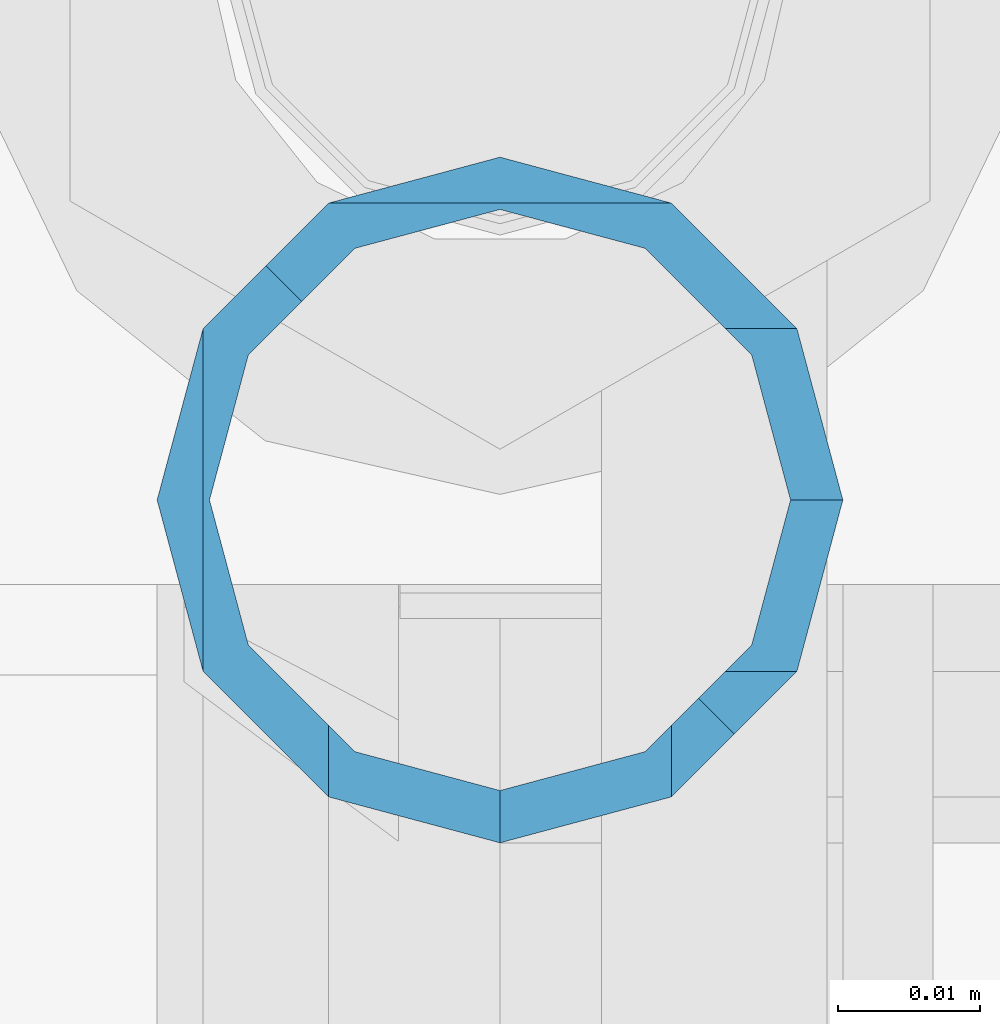
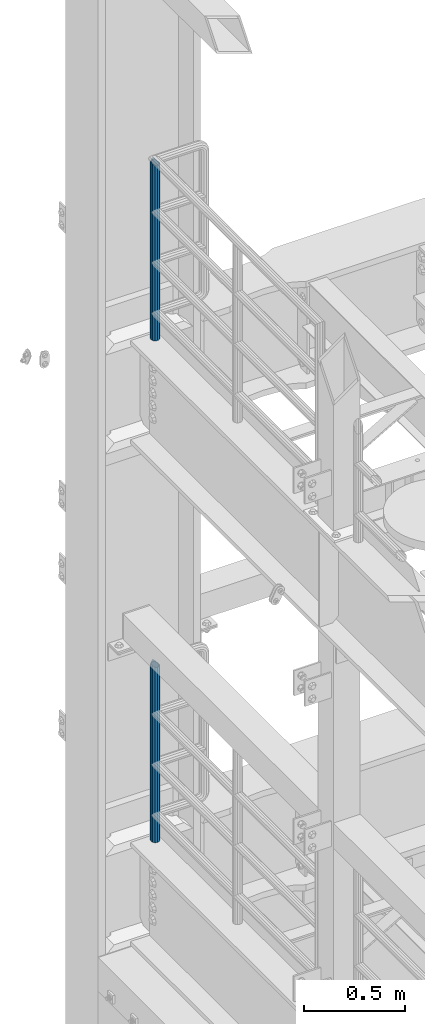
# One storey, part 748 of 1876: 2 columns, 2 elements without a shape of their own.
"""IFC2X3 building model written with IfcOpenShell, lengths in millimetres."""

from ifc_helpers import new_model, si_unit, frame, origin_with_axes, place, context, subcontext, project, spatial, faceted_brep, material, type_object, element, aggregate, save


model = new_model("IFC2X3")

# Units and contexts
model_context = context("Model", 3, precision=1e-05, world=origin_with_axes())
body_context = subcontext(model_context, "Body", "Model", "MODEL_VIEW")
ifc_project = project(units=[si_unit("LENGTHUNIT", "METRE", prefix="MILLI"), si_unit("AREAUNIT", "SQUARE_METRE"), si_unit("VOLUMEUNIT", "CUBIC_METRE"), si_unit("MASSUNIT", "GRAM", prefix="KILO"), si_unit("TIMEUNIT", "SECOND"), si_unit("PLANEANGLEUNIT", "RADIAN"), si_unit("SOLIDANGLEUNIT", "STERADIAN"), si_unit("THERMODYNAMICTEMPERATUREUNIT", "DEGREE_CELSIUS"), si_unit("LUMINOUSINTENSITYUNIT", "LUMEN")], contexts=[model_context])

# Site, building, storey
site_placement = place(None, origin_with_axes())
site = spatial("IfcSite", under=ifc_project, at=site_placement, CompositionType="ELEMENT")
building_placement = place(site_placement, origin_with_axes())
building = spatial("IfcBuilding", under=site, at=building_placement, Name="Undefined", CompositionType="ELEMENT")
storey_placement = place(building_placement, origin_with_axes())
storey = spatial("IfcBuildingStorey", under=building, at=storey_placement, Name="Undefined", CompositionType="ELEMENT", Elevation=0.0)

# Assembly, column
assembly_1_placement = place(storey_placement, origin_with_axes())
assembly_1 = element("IfcElementAssembly", 1, at=assembly_1_placement, inside=storey, Name="RAIL", AssemblyPlace="NOTDEFINED", PredefinedType="RIGID_FRAME")
ifc_material = material()
column_type = type_object("IfcColumnType", Name="PIPE1-1/2SCH40", PredefinedType="NOTDEFINED")
column_1_placement = place(assembly_1_placement, frame((-1.81898940354586e-12, 13499.7063, 8153.4), z_axis=(0.0, 1.0, 0.0), x_axis=(0.0, 0.0, 1.0)))
column_1 = element("IfcColumn", 2, at=column_1_placement, type_object=column_type, material=ifc_material, Name="POST", ObjectType="PIPE1-1/2SCH40", context=body_context, shape_type="Brep", body=[
    faceted_brep([(1076.325, -24.1300000000001, 0.0), (1064.25999999999, -20.8971929933186, -12.0649999999996), (1064.26, -20.8971929933184, 12.0649999999996), (1054.93437856882, 17.7076214311801, 10.2235000000001), (1052.195, 20.4470000000001, 0.0), (1052.195, 24.13, 0.0), (1055.42780700668, 20.8971929933185, 12.0649999999996), (1055.42780700668, 15.8661214311869, 12.0649999999932), (1055.42780700668, 15.8661214311742, -12.065000000006), (1055.42780700668, 20.8971929933185, -12.0649999999996), (1054.93437856882, 17.7076214311801, -10.2235000000001), (1057.32837749232, 13.9655704718316, -13.9655509593485), (1059.84391327712, 16.4811062541432, -16.4810867391752), (1055.42780700668, 12.0650000000001, -15.8661214311805), (1055.42780700667, 12.0649999999996, -20.8971929933186), (1054.93437856882, 10.2235000000001, -17.7076214311801), (1052.195, 0.0, -20.4470000000001), (1052.19499999999, 0.0, -24.1300000000001), (1055.42780700668, -12.0650000000001, -15.8661214311805), (1055.42780700667, -12.0649999999996, -20.8971929933186), (1054.93437856882, -10.2235000000001, -17.7076214311801), (1061.07042843786, -17.7076214311803, -10.2235000000001), (1063.80980700668, -20.4469999999999, 0.0), (1061.07042843786, -17.7076214311803, 10.2235000000001), (1057.32835795223, -13.9655509593467, 13.9655704718334), (1059.84389372957, -16.4810867391727, 16.4811062541457), (1076.325, 0.0, 24.1300000000001), (1064.26, -12.0650000000001, 20.8971929933186), (1064.26, 12.065, 20.8971929933186), (1061.07042843787, -10.2235000000001, 17.7076214311801), (1063.80980700669, 0.0, 20.4470000000001), (1061.07042843787, 10.2235000000001, 17.7076214311801), (0.0, -20.8971929933184, -12.0649999999996), (0.0, -12.0650000000001, -20.8971929933186), (-1.45519152283669e-11, 0.0, -24.130000000001), (0.0, 12.0650000000001, -20.8971929933186), (0.0, 20.8971929933184, -12.0649999999996), (0.0, 24.1299999999992, 0.0), (0.0, 20.8971929933184, 12.0649999999996), (0.0, 12.0650000000001, 20.8971929933186), (-1.45519152283669e-11, 0.0, 24.130000000001), (0.0, -20.8971929933184, 12.0649999999996), (0.0, -24.1299999999992, 0.0), (0.0, -12.0650000000001, 20.8971929933186), (0.0, -17.7076214311803, -10.2235000000001), (0.0, -10.2235000000001, -17.7076214311801), (-1.45519152283669e-11, 0.0, -20.4470000000001), (0.0, 10.2235000000001, -17.7076214311801), (0.0, 17.7076214311803, -10.2235000000001), (0.0, 20.4469999999999, 0.0), (0.0, 17.7076214311803, 10.2235000000001), (0.0, 10.2235000000001, 17.7076214311801), (-1.45519152283669e-11, 0.0, 20.4470000000001), (0.0, -10.2235000000001, 17.7076214311801), (0.0, -17.7076214311803, 10.2235000000001), (0.0, -20.4469999999999, 0.0)], [[[0, 1, 2]], [[3, 4, 5, 6, 7]], [[8, 9, 5, 4, 10]], [[9, 8, 11, 12]], [[12, 11, 13, 14]], [[15, 16, 17, 14, 13]], [[18, 19, 17, 16, 20]], [[2, 1, 19, 18, 21, 22, 23, 24, 25]], [[26, 27, 28]], [[25, 24, 29, 30, 31, 7, 6, 28, 27]], [[32, 33, 19, 1]], [[33, 34, 17, 19]], [[34, 35, 14, 17]], [[35, 36, 9, 12, 14]], [[36, 37, 5, 9]], [[37, 38, 6, 5]], [[38, 39, 28, 6]], [[39, 40, 26, 28]], [[41, 42, 0, 2]], [[43, 41, 2, 25, 27]], [[40, 43, 27, 26]], [[42, 32, 1, 0]], [[41, 43, 40, 39, 38, 37, 36, 35, 34, 33, 32, 42], [44, 45, 46, 47, 48, 49, 50, 51, 52, 53, 54, 55]], [[53, 52, 30, 29]], [[23, 54, 53, 29, 24]], [[55, 54, 23, 22]], [[44, 55, 22, 21]], [[20, 45, 44, 21, 18]], [[46, 45, 20, 16]], [[47, 46, 16, 15]], [[10, 48, 47, 15, 13, 11, 8]], [[49, 48, 10, 4]], [[50, 49, 4, 3]], [[51, 50, 3, 7, 31]], [[52, 51, 31, 30]]]),
])
aggregate(assembly_1, [column_1])

assembly_2_placement = place(storey_placement, origin_with_axes())
assembly_2 = element("IfcElementAssembly", 3, at=assembly_2_placement, inside=storey, Name="RAIL", AssemblyPlace="NOTDEFINED", PredefinedType="RIGID_FRAME")
column_2_placement = place(assembly_2_placement, frame((-1.81898940354586e-12, 13499.7063, 5130.8), z_axis=(0.0, 1.0, 0.0), x_axis=(0.0, 0.0, 1.0)))
column_2 = element("IfcColumn", 4, at=column_2_placement, type_object=column_type, material=ifc_material, Name="POST", ObjectType="PIPE1-1/2SCH40", context=body_context, shape_type="Brep", body=[
    faceted_brep([(1076.325, -24.1300000000001, 0.0), (1064.25999999999, -20.8971929933186, -12.0649999999996), (1064.26, -20.8971929933184, 12.0649999999996), (1054.93437856882, 17.7076214311801, 10.2235000000001), (1052.195, 20.4470000000001, 0.0), (1052.195, 24.13, 0.0), (1055.42780700668, 20.8971929933185, 12.0649999999996), (1055.42780700668, 15.8661214311869, 12.0649999999932), (1055.42780700668, 15.8661214311742, -12.065000000006), (1055.42780700668, 20.8971929933185, -12.0649999999996), (1054.93437856882, 17.7076214311801, -10.2235000000001), (1057.32837749232, 13.9655704718316, -13.9655509593485), (1059.84391327712, 16.4811062541432, -16.4810867391752), (1055.42780700668, 12.0650000000001, -15.8661214311805), (1055.42780700667, 12.0649999999996, -20.8971929933186), (1054.93437856882, 10.2235000000001, -17.7076214311801), (1052.195, 0.0, -20.4470000000001), (1052.19499999999, 0.0, -24.1300000000001), (1055.42780700668, -12.0650000000001, -15.8661214311805), (1055.42780700667, -12.0649999999996, -20.8971929933186), (1054.93437856882, -10.2235000000001, -17.7076214311801), (1061.07042843786, -17.7076214311803, -10.2235000000001), (1063.80980700668, -20.4469999999999, 0.0), (1061.07042843786, -17.7076214311803, 10.2235000000001), (1057.32835795223, -13.9655509593467, 13.9655704718334), (1059.84389372957, -16.4810867391727, 16.4811062541457), (1076.325, 0.0, 24.1300000000001), (1064.26, -12.0650000000001, 20.8971929933186), (1064.26, 12.065, 20.8971929933186), (1061.07042843787, -10.2235000000001, 17.7076214311801), (1063.80980700669, 0.0, 20.4470000000001), (1061.07042843787, 10.2235000000001, 17.7076214311801), (0.0, -20.8971929933184, -12.0649999999996), (0.0, -12.0650000000001, -20.8971929933186), (-1.45519152283669e-11, 0.0, -24.130000000001), (0.0, 12.0650000000001, -20.8971929933186), (0.0, 20.8971929933184, -12.0649999999996), (0.0, 24.1299999999992, 0.0), (0.0, 20.8971929933184, 12.0649999999996), (0.0, 12.0650000000001, 20.8971929933186), (-1.45519152283669e-11, 0.0, 24.130000000001), (0.0, -20.8971929933184, 12.0649999999996), (0.0, -24.1299999999992, 0.0), (0.0, -12.0650000000001, 20.8971929933186), (0.0, -17.7076214311803, -10.2235000000001), (0.0, -10.2235000000001, -17.7076214311801), (-1.45519152283669e-11, 0.0, -20.4470000000001), (0.0, 10.2235000000001, -17.7076214311801), (0.0, 17.7076214311803, -10.2235000000001), (0.0, 20.4469999999999, 0.0), (0.0, 17.7076214311803, 10.2235000000001), (0.0, 10.2235000000001, 17.7076214311801), (-1.45519152283669e-11, 0.0, 20.4470000000001), (0.0, -10.2235000000001, 17.7076214311801), (0.0, -17.7076214311803, 10.2235000000001), (0.0, -20.4469999999999, 0.0)], [[[0, 1, 2]], [[3, 4, 5, 6, 7]], [[8, 9, 5, 4, 10]], [[9, 8, 11, 12]], [[12, 11, 13, 14]], [[15, 16, 17, 14, 13]], [[18, 19, 17, 16, 20]], [[2, 1, 19, 18, 21, 22, 23, 24, 25]], [[26, 27, 28]], [[25, 24, 29, 30, 31, 7, 6, 28, 27]], [[32, 33, 19, 1]], [[33, 34, 17, 19]], [[34, 35, 14, 17]], [[35, 36, 9, 12, 14]], [[36, 37, 5, 9]], [[37, 38, 6, 5]], [[38, 39, 28, 6]], [[39, 40, 26, 28]], [[41, 42, 0, 2]], [[43, 41, 2, 25, 27]], [[40, 43, 27, 26]], [[42, 32, 1, 0]], [[41, 43, 40, 39, 38, 37, 36, 35, 34, 33, 32, 42], [44, 45, 46, 47, 48, 49, 50, 51, 52, 53, 54, 55]], [[53, 52, 30, 29]], [[23, 54, 53, 29, 24]], [[55, 54, 23, 22]], [[44, 55, 22, 21]], [[20, 45, 44, 21, 18]], [[46, 45, 20, 16]], [[47, 46, 16, 15]], [[10, 48, 47, 15, 13, 11, 8]], [[49, 48, 10, 4]], [[50, 49, 4, 3]], [[51, 50, 3, 7, 31]], [[52, 51, 31, 30]]]),
])
aggregate(assembly_2, [column_2])

save(model, "model.ifc")
